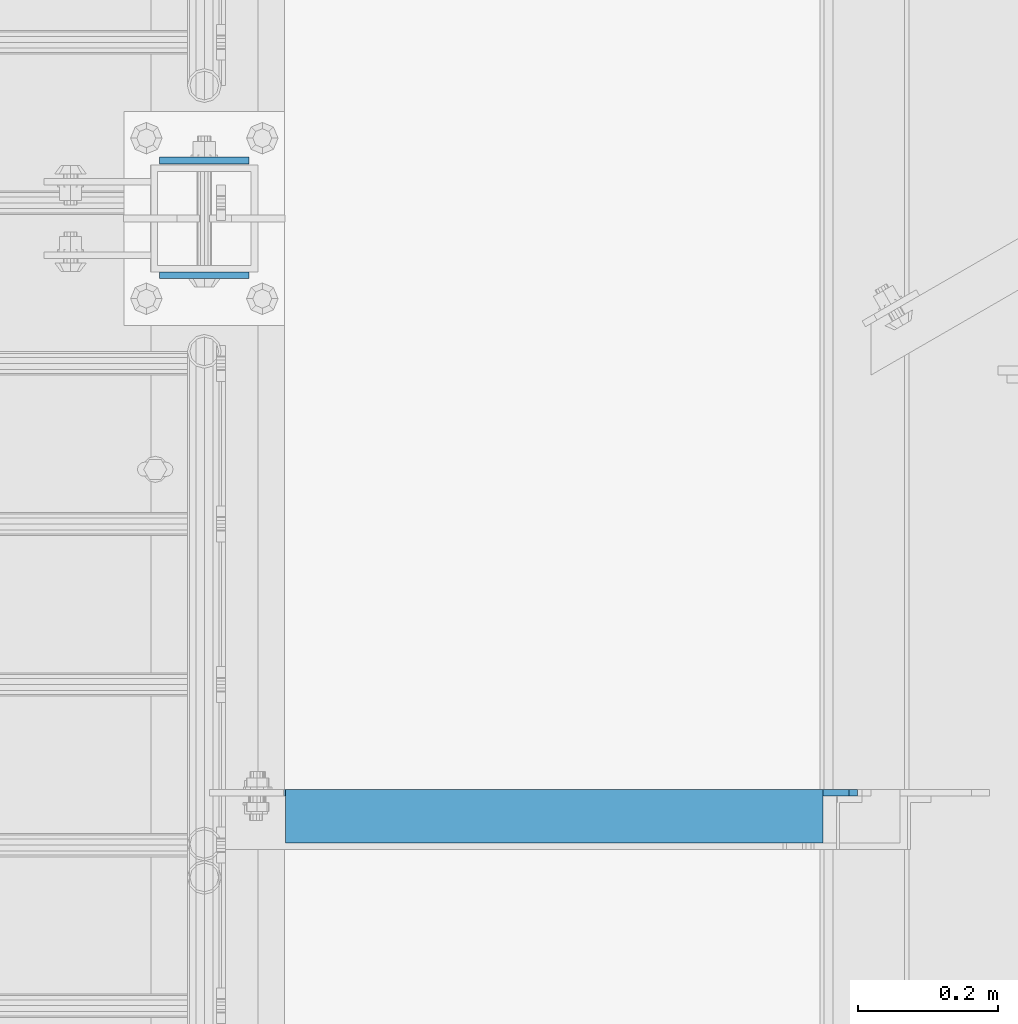
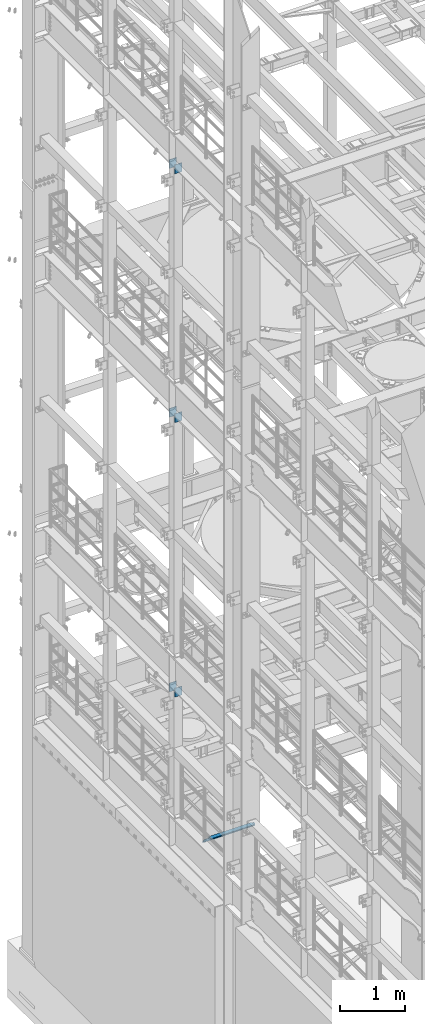
# One storey, part 1294 of 1876: 7 beams, 4 elements without a shape of their own.
"""IFC2X3 building model written with IfcOpenShell, lengths in millimetres."""

from ifc_helpers import new_model, si_unit, frame, origin_with_axes, place, context, subcontext, project, spatial, faceted_brep, material, type_object, element, aggregate, save


model = new_model("IFC2X3")

# Units and contexts
model_context = context("Model", 3, precision=1e-05, world=origin_with_axes())
body_context = subcontext(model_context, "Body", "Model", "MODEL_VIEW")
ifc_project = project(units=[si_unit("LENGTHUNIT", "METRE", prefix="MILLI"), si_unit("AREAUNIT", "SQUARE_METRE"), si_unit("VOLUMEUNIT", "CUBIC_METRE"), si_unit("MASSUNIT", "GRAM", prefix="KILO"), si_unit("TIMEUNIT", "SECOND"), si_unit("PLANEANGLEUNIT", "RADIAN"), si_unit("SOLIDANGLEUNIT", "STERADIAN"), si_unit("THERMODYNAMICTEMPERATUREUNIT", "DEGREE_CELSIUS"), si_unit("LUMINOUSINTENSITYUNIT", "LUMEN")], contexts=[model_context])

# Site, building, storey
site_placement = place(None, origin_with_axes())
site = spatial("IfcSite", under=ifc_project, at=site_placement, CompositionType="ELEMENT")
building_placement = place(site_placement, origin_with_axes())
building = spatial("IfcBuilding", under=site, at=building_placement, Name="Undefined", CompositionType="ELEMENT")
storey_placement = place(building_placement, origin_with_axes())
storey = spatial("IfcBuildingStorey", under=building, at=storey_placement, Name="Undefined", CompositionType="ELEMENT", Elevation=0.0)

# Assembly, beams
assembly_1_placement = place(storey_placement, origin_with_axes())
assembly_1 = element("IfcElementAssembly", 1, at=assembly_1_placement, inside=storey, Name="BEAM", AssemblyPlace="NOTDEFINED", PredefinedType="RIGID_FRAME")
ifc_material = material(Name="STEEL/A36")
beam_type_1 = type_object("IfcBeamType", PredefinedType="NOTDEFINED")
beam_1_placement = place(assembly_1_placement, frame((-63.6296757345187, 9734.55, 7448.54714244377), z_axis=(5.59490000219896e-05, 0.0, -0.999999998434855), x_axis=(0.999999998434855, 0.0, 5.59490000219868e-05)))
beam_1 = element("IfcBeam", 2, at=beam_1_placement, type_object=beam_type_1, material=ifc_material, Name="PLATE", context=body_context, shape_type="Brep", body=[
    faceted_brep([(0.0, 4.76249999999982, -82.5499999999993), (0.0, 4.76249999999982, 82.5499999999993), (127.0, 4.76249999999982, 82.5499999999993), (127.0, 4.76249999999982, -82.5499999999993), (0.0, -4.76249999999982, 82.5499999999993), (127.0, -4.76249999999982, 82.5499999999993), (0.0, -4.76249999999982, -82.5499999999993), (127.0, -4.76249999999982, -82.5499999999993)], [[[0, 1, 2, 3]], [[1, 4, 5, 2]], [[4, 6, 7, 5]], [[6, 0, 3, 7]], [[5, 7, 3, 2]], [[6, 4, 1, 0]]]),
])
beam_2_placement = place(assembly_1_placement, frame((-63.6296757345187, 9571.0375, 7448.54714244377), z_axis=(5.59490000219896e-05, 0.0, -0.999999998434855), x_axis=(0.999999998434855, 0.0, 5.59490000219868e-05)))
beam_2 = element("IfcBeam", 3, at=beam_2_placement, type_object=beam_type_1, material=ifc_material, Name="PLATE", context=body_context, shape_type="Brep", body=[
    faceted_brep([(0.0, 4.76249999999982, -82.5499999999993), (0.0, 4.76249999999982, 82.5499999999993), (127.0, 4.76249999999982, 82.5499999999993), (127.0, 4.76249999999982, -82.5499999999993), (0.0, -4.76249999999982, 82.5499999999993), (127.0, -4.76249999999982, 82.5499999999993), (0.0, -4.76249999999982, -82.5499999999993), (127.0, -4.76249999999982, -82.5499999999993)], [[[0, 1, 2, 3]], [[1, 4, 5, 2]], [[4, 6, 7, 5]], [[6, 0, 3, 7]], [[5, 7, 3, 2]], [[6, 4, 1, 0]]]),
])
aggregate(assembly_1, [beam_1, beam_2])

assembly_2_placement = place(storey_placement, origin_with_axes())
assembly_2 = element("IfcElementAssembly", 4, at=assembly_2_placement, inside=storey, Name="BEAM", AssemblyPlace="NOTDEFINED", PredefinedType="RIGID_FRAME")
beam_3_placement = place(assembly_2_placement, frame((-63.6315195800257, 9734.55, 12604.7488224823), z_axis=(2.95459999824743e-05, 0.0, -0.999999999563517), x_axis=(0.999999999563517, 0.0, 2.95459999828704e-05)))
beam_3 = element("IfcBeam", 5, at=beam_3_placement, type_object=beam_type_1, material=ifc_material, Name="PLATE", context=body_context, shape_type="Brep", body=[
    faceted_brep([(0.0, 4.76249999999982, -82.5499999999993), (0.0, 4.76249999999982, 82.5499999999993), (127.0, 4.76249999999982, 82.5499999999993), (127.0, 4.76249999999982, -82.5499999999993), (0.0, -4.76249999999982, 82.5499999999993), (127.0, -4.76249999999982, 82.5499999999993), (0.0, -4.76249999999982, -82.5499999999993), (127.0, -4.76249999999982, -82.5499999999993)], [[[0, 1, 2, 3]], [[1, 4, 5, 2]], [[4, 6, 7, 5]], [[6, 0, 3, 7]], [[5, 7, 3, 2]], [[6, 4, 1, 0]]]),
])
beam_4_placement = place(assembly_2_placement, frame((-63.6315195800257, 9571.0375, 12604.7488224823), z_axis=(2.95459999824743e-05, 0.0, -0.999999999563517), x_axis=(0.999999999563517, 0.0, 2.95459999828704e-05)))
beam_4 = element("IfcBeam", 6, at=beam_4_placement, type_object=beam_type_1, material=ifc_material, Name="PLATE", context=body_context, shape_type="Brep", body=[
    faceted_brep([(0.0, 4.76249999999982, -82.5499999999993), (0.0, 4.76249999999982, 82.5499999999993), (127.0, 4.76249999999982, 82.5499999999993), (127.0, 4.76249999999982, -82.5499999999993), (0.0, -4.76249999999982, 82.5499999999993), (127.0, -4.76249999999982, 82.5499999999993), (0.0, -4.76249999999982, -82.5499999999993), (127.0, -4.76249999999982, -82.5499999999993)], [[[0, 1, 2, 3]], [[1, 4, 5, 2]], [[4, 6, 7, 5]], [[6, 0, 3, 7]], [[5, 7, 3, 2]], [[6, 4, 1, 0]]]),
])
aggregate(assembly_2, [beam_3, beam_4])

assembly_3_placement = place(storey_placement, origin_with_axes())
assembly_3 = element("IfcElementAssembly", 7, at=assembly_3_placement, inside=storey, Name="BEAM", AssemblyPlace="NOTDEFINED", PredefinedType="RIGID_FRAME")
beam_5_placement = place(assembly_3_placement, frame((-63.5, 9734.55, 17278.35), z_axis=(0.0, 0.0, -1.0), x_axis=(1.0, 0.0, 0.0)))
beam_5 = element("IfcBeam", 8, at=beam_5_placement, type_object=beam_type_1, material=ifc_material, Name="PLATE", context=body_context, shape_type="Brep", body=[
    faceted_brep([(0.0, 4.76249999999982, -82.5499999999993), (0.0, 4.76249999999982, 82.5499999999993), (127.0, 4.76249999999982, 82.5499999999993), (127.0, 4.76249999999982, -82.5499999999993), (0.0, -4.76249999999982, 82.5499999999993), (127.0, -4.76249999999982, 82.5499999999993), (0.0, -4.76249999999982, -82.5499999999993), (127.0, -4.76249999999982, -82.5499999999993)], [[[0, 1, 2, 3]], [[1, 4, 5, 2]], [[4, 6, 7, 5]], [[6, 0, 3, 7]], [[5, 7, 3, 2]], [[6, 4, 1, 0]]]),
])
beam_6_placement = place(assembly_3_placement, frame((-63.5, 9571.0375, 17278.35), z_axis=(0.0, 0.0, -1.0), x_axis=(1.0, 0.0, 0.0)))
beam_6 = element("IfcBeam", 9, at=beam_6_placement, type_object=beam_type_1, material=ifc_material, Name="PLATE", context=body_context, shape_type="Brep", body=[
    faceted_brep([(0.0, 4.76249999999982, -82.5499999999993), (0.0, 4.76249999999982, 82.5499999999993), (127.0, 4.76249999999982, 82.5499999999993), (127.0, 4.76249999999982, -82.5499999999993), (0.0, -4.76249999999982, 82.5499999999993), (127.0, -4.76249999999982, 82.5499999999993), (0.0, -4.76249999999982, -82.5499999999993), (127.0, -4.76249999999982, -82.5499999999993)], [[[0, 1, 2, 3]], [[1, 4, 5, 2]], [[4, 6, 7, 5]], [[6, 0, 3, 7]], [[5, 7, 3, 2]], [[6, 4, 1, 0]]]),
])
aggregate(assembly_3, [beam_5, beam_6])

# Assembly, beam
assembly_4_placement = place(storey_placement, origin_with_axes())
assembly_4 = element("IfcElementAssembly", 10, at=assembly_4_placement, inside=storey, Name="ANGLE", AssemblyPlace="NOTDEFINED", PredefinedType="RIGID_FRAME")
beam_type_2 = type_object("IfcBeamType", Name="L3X3X3/8", PredefinedType="NOTDEFINED")
beam_7_placement = place(assembly_4_placement, frame((0.0, 8801.1, 5092.7), z_axis=(0.0, -1.0, 0.0), x_axis=(1.0, 0.0, 0.0)))
beam_7 = element("IfcBeam", 11, at=beam_7_placement, type_object=beam_type_2, material=ifc_material, Name="ANGLE", ObjectType="L3X3X3/8", context=body_context, shape_type="Brep", body=[
    faceted_brep([(115.886999817316, 28.5750000000007, 38.0999999999999), (115.886999817316, 38.0999999999985, 38.0999999999999), (115.886998826692, 38.0999999999985, -38.0999999999999), (115.88699882669, 12.699999237062, -38.0999999999999), (115.886998950515, 12.699999237062, -28.5749999999998), (115.88699895052, 28.5750000000007, -28.5749999999998), (38.8937432114558, 12.699999237062, -38.0999999999999), (38.8937433352807, 12.699999237062, -28.5749999999998), (7.14374321145577, -19.050000762938, -38.0999999999999), (7.14374333528067, -19.050000762938, -28.5749999999998), (7.1437499954859, -38.0999999999985, -38.0999999999999), (7.1437499954859, -38.0999999999985, -28.5749999999998), (930.275002424124, 15.8750003814703, -28.5750000000007), (917.575002614859, 28.5749999999998, -28.5750000000007), (881.063000623622, 28.5749999999998, -28.5750000000007), (930.274999999999, -38.1000000000004, -28.5750000000007), (930.275002424124, 3.17500152587945, -28.5750000000007), (881.063002423843, 28.5749999999998, 38.1000000000004), (881.063002423821, 38.1000000000004, 38.1000000000004), (881.063000366478, 38.1000000000004, -38.1000000000004), (881.063000366447, 28.5750001907354, -38.1000000000004), (917.575002357685, 28.5750001907354, -38.1000000000004), (930.27500216695, 15.8750003814703, -38.1000000000004), (930.27500216695, 3.17500152587945, -38.1000000000004), (930.274999999999, -38.1000000000004, -38.1000000000004)], [[[0, 1, 2, 3, 4, 5]], [[4, 3, 6, 7]], [[7, 6, 8, 9]], [[8, 10, 11, 9]], [[12, 13, 14, 5, 4, 7, 9, 11, 15, 16]], [[0, 5, 14, 17]], [[1, 0, 17, 18]], [[2, 1, 18, 19]], [[17, 14, 20, 19, 18]], [[13, 21, 20, 14]], [[12, 22, 21, 13]], [[16, 23, 22, 12]], [[10, 8, 6, 3, 2, 19, 20, 21, 22, 23, 24]], [[11, 10, 24, 15]], [[23, 16, 15, 24]]]),
])
aggregate(assembly_4, [beam_7])

save(model, "model.ifc")
